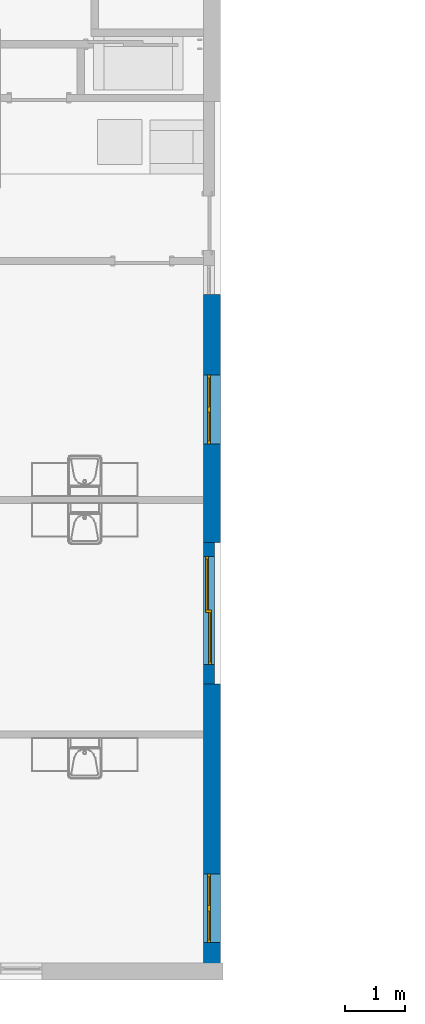
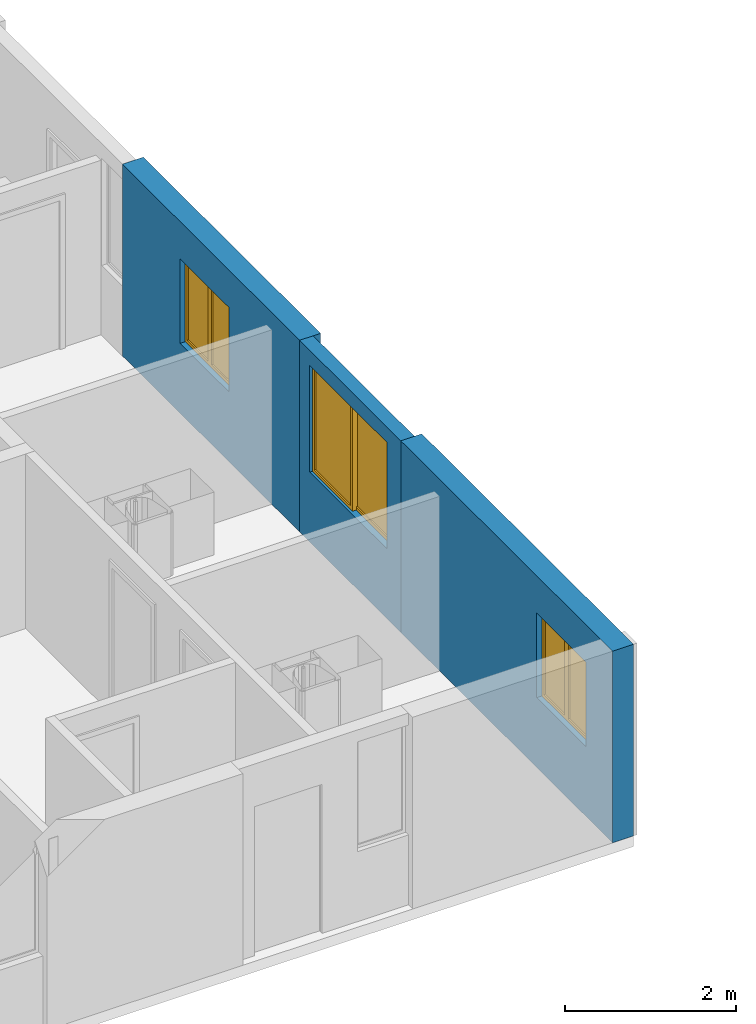
# One storey, part 9 of 64: 3 walls, 3 windows, 3 openings.
"""IFC4 building model written with IfcOpenShell, lengths in feet."""

from ifc_helpers import new_model, entity, si_unit, converted_unit, frame, origin_with_axes, origin_2d_with_axis, place, context, subcontext, project, spatial, line, indexed_curve, outline, extrude, polygons, source, transform, mapped, material, layer, layer_set, layer_usage, type_object, type_shapes, element, fill, save


model = new_model("IFC4")

# Units and contexts
model_context = context("Model", 3, precision=1e-05, world=origin_with_axes())
plan_context = context("Plan", 2, precision=1e-05, world=origin_2d_with_axis())
context_of_model_1 = context(None, 3, precision=1e-05, world=origin_with_axes())
context_of_model_2 = context(None, 3, precision=1e-05, world=origin_with_axes())
body_context = subcontext(model_context, "Body", "Model", "MODEL_VIEW")
ifc_project = project(units=[converted_unit("PLANEANGLEUNIT", "degree", entity("IfcReal", 0.0174532925199433), si_unit("PLANEANGLEUNIT", "RADIAN"), dimensions=[0, 0, 0, 0, 0, 0, 0]), converted_unit("AREAUNIT", "square foot", entity("IfcReal", 0.09290304), si_unit("AREAUNIT", "SQUARE_METRE"), dimensions=[2, 0, 0, 0, 0, 0, 0]), converted_unit("LENGTHUNIT", "foot", entity("IfcReal", 0.3048), si_unit("LENGTHUNIT", "METRE"), dimensions=[1, 0, 0, 0, 0, 0, 0]), converted_unit("VOLUMEUNIT", "cubic foot", entity("IfcReal", 0.0283168467116885), si_unit("VOLUMEUNIT", "CUBIC_METRE"), dimensions=[3, 0, 0, 0, 0, 0, 0])], contexts=[model_context, plan_context, context_of_model_1, context_of_model_2])

# Site, building, storey
site_placement = place(None, origin_with_axes())
site = spatial("IfcSite", under=ifc_project, at=site_placement)
building_placement = place(site_placement, origin_with_axes())
building = spatial("IfcBuilding", under=site, at=building_placement, Name="Building")
storey_placement = place(building_placement, origin_with_axes())
storey = spatial("IfcBuildingStorey", under=building, at=storey_placement, Name="Storey")

# Wall, opening, window
ifc_material_1 = material()
ifc_layer_1 = layer(ifc_material_1, 0.0520833333333333)
ifc_material_2 = material()
ifc_layer_2 = layer(ifc_material_2, 0.458332985639572)
ifc_layer_3 = layer(ifc_material_1, 0.0520833320915699)
ifc_material_3 = material(Name="SPACE")
ifc_layer_4 = layer(ifc_material_3, 0.0416669994592667, Name="Air Gap")
ifc_material_4 = material()
ifc_layer_5 = layer(ifc_material_4, 0.328083992004395)
ifc_layer_set_1 = layer_set([ifc_layer_1, ifc_layer_2, ifc_layer_3, ifc_layer_4, ifc_layer_5], Name="poche")
ifc_layer_usage_1 = layer_usage(ifc_layer_set_1, "AXIS2", "POSITIVE", 0.0)
wall_type_1 = type_object("IfcWallType", PredefinedType="STANDARD", material=ifc_layer_set_1)
wall_1_placement = place(storey_placement, frame((-241.163509098564, 4.3808694273781, 0.0), z_axis=(0.0, 0.0, 1.0), x_axis=(3.13916473260163e-07, -0.999999999999951, 0.0)))
wall_1 = element("IfcWall", 1, at=wall_1_placement, inside=storey, type_object=wall_type_1, material=ifc_layer_usage_1, Name="Wall", context=body_context, shape_type="SweptSolid", body=[
    extrude(outline(indexed_curve([(0.0, 0.0), (0.0, 0.932250642528137), (13.6428727412722, 0.932250642528137), (13.6428727412722, 0.0), (0.0, 0.0)], self_intersect=False)), origin_with_axes(), (0.0, 0.0, 1.0), 9.00000020900736),
])
shared_shape_1 = source(origin_with_axes(), body_context, "Body", "SweptSolid", [
    extrude(outline(indexed_curve([(0.0, 0.0), (3.77686476707458, 0.0), (3.77686476707458, 3.96558260917664), (0.0, 3.96558260917664)], segments=[line(1, 2, 3, 4, 1)])), frame((0.0, -0.328083992004395, 0.0), z_axis=(0.0, -1.0, 0.0), x_axis=(1.0, 0.0, 0.0)), (0.0, 0.0, -1.0), 1.58841864956333),
])
opening_1_placement = place(wall_1_placement, frame((4.44922429995878, -1.39668497240116e-06, 3.28083989501312), z_axis=(0.0, 0.0, 1.0), x_axis=(1.0, 5.29395592033938e-23, 0.0)))
opening_1 = element("IfcOpeningElement", 2, at=opening_1_placement, cuts=wall_1, Name="Opening", PredefinedType="OPENING", context=body_context, shape_type="MappedRepresentation", body=[
    mapped(shared_shape_1, transform((0.0, 0.0, 0.0), x_axis=(1.0, 0.0, 0.0), y_axis=(0.0, 1.0, 0.0), z_axis=(0.0, 0.0, 1.0), scale=1.0)),
])
window_type_1 = type_object("IfcWindowType", PartitioningType="NOTDEFINED", PredefinedType="NOTDEFINED")
shared_shape_2 = source(origin_with_axes(), body_context, "Body", "Tessellation", [
    polygons([(0.15000008046627, 0.164041996002197, 3.81558227539062), (0.15000008046627, 0.164041996002197, 0.149999901652336), (0.0, 0.164041996002197, 0.0), (0.0, 0.164041996002197, 3.96558260917664), (0.0, 0.0, 0.0), (0.0, 0.0, 3.96558260917664), (0.15000008046627, 7.7842932100225e-09, 3.81558227539062), (0.15000008046627, 7.7842932100225e-09, 0.149999901652336), (1.73843264579773, 6.58808829712143e-08, 3.81558227539062), (1.88843274116516, 7.36651841748426e-08, 0.0), (1.88843274116516, 7.36651841748426e-08, 3.96558260917664), (1.73843264579773, 6.58808829712143e-08, 0.149999901652336), (1.88843274116516, 0.164042070508003, 3.96558260917664), (1.88843274116516, 0.164042070508003, 0.0), (1.73843264579773, 0.164042070508003, 0.149999901652336), (1.73843264579773, 0.164042070508003, 3.81558227539062), (1.73843264579773, 0.0656168609857559, 0.149999901652336), (0.15000008046627, 0.0656168088316917, 3.81558227539062), (1.73843264579773, 0.0656168609857559, 3.81558227539062), (0.15000008046627, 0.0656168088316917, 0.149999901652336), (1.73843264579773, 0.0984252616763115, 3.81558227539062), (1.73843264579773, 0.0984252616763115, 0.149999901652336), (0.15000008046627, 0.0984252095222473, 0.149999901652336), (0.15000008046627, 0.0984252095222473, 3.81558227539062), (2.03843188285828, 0.164042085409164, 3.81558227539062), (2.03843188285828, 0.164042085409164, 0.149999901652336), (1.88843202590942, 0.164042085409164, 0.0), (1.88843202590942, 0.164042085409164, 3.96558260917664), (1.88843202590942, 8.25459736120138e-08, 0.0), (1.88843202590942, 8.25459736120138e-08, 3.96558260917664), (2.03843188285828, 9.03302606047873e-08, 3.81558227539062), (2.03843188285828, 9.03302606047873e-08, 0.149999901652336), (3.62686443328857, 1.48426849477801e-07, 3.81558227539062), (3.77686476707458, 1.56211143576002e-07, 0.0), (3.77686476707458, 1.56211143576002e-07, 3.96558260917664), (3.62686443328857, 1.48426849477801e-07, 0.149999901652336), (3.77686476707458, 0.16404215991497, 3.96558260917664), (3.77686476707458, 0.16404215991497, 0.0), (3.62686443328857, 0.16404215991497, 0.149999901652336), (3.62686443328857, 0.16404215991497, 3.81558227539062), (3.62686443328857, 0.0656169503927231, 0.149999901652336), (2.03843188285828, 0.0656168982386589, 3.81558227539062), (3.62686443328857, 0.0656169503927231, 3.81558227539062), (2.03843188285828, 0.0656168982386589, 0.149999901652336), (3.62686443328857, 0.0984253510832787, 3.81558227539062), (3.62686443328857, 0.0984253510832787, 0.149999901652336), (2.03843188285828, 0.0984252914786339, 0.149999901652336), (2.03843188285828, 0.0984252914786339, 3.81558227539062)], [[[2, 3, 1]], [[4, 1, 3]], [[5, 7, 6]], [[5, 8, 7]], [[10, 11, 9]], [[12, 10, 9]], [[7, 11, 6]], [[7, 9, 11]], [[8, 10, 12]], [[5, 10, 8]], [[14, 15, 13]], [[15, 16, 13]], [[16, 1, 13]], [[13, 1, 4]], [[14, 3, 2]], [[14, 2, 15]], [[3, 10, 5]], [[3, 14, 10]], [[11, 10, 14]], [[11, 14, 13]], [[8, 12, 15]], [[15, 2, 8]], [[15, 9, 16]], [[12, 9, 15]], [[4, 6, 11]], [[4, 11, 13]], [[5, 6, 4]], [[5, 4, 3]], [[1, 9, 7]], [[1, 16, 9]], [[7, 8, 2]], [[7, 2, 1]], [[26, 27, 25]], [[28, 25, 27]], [[29, 31, 30]], [[29, 32, 31]], [[34, 35, 33]], [[36, 34, 33]], [[31, 35, 30]], [[31, 33, 35]], [[32, 34, 36]], [[29, 34, 32]], [[38, 39, 37]], [[39, 40, 37]], [[40, 25, 37]], [[37, 25, 28]], [[38, 27, 26]], [[38, 26, 39]], [[27, 34, 29]], [[27, 38, 34]], [[35, 34, 38]], [[35, 38, 37]], [[32, 36, 39]], [[39, 26, 32]], [[39, 33, 40]], [[36, 33, 39]], [[28, 30, 35]], [[28, 35, 37]], [[29, 30, 28]], [[29, 28, 27]], [[25, 33, 31]], [[25, 40, 33]], [[31, 32, 26]], [[31, 26, 25]]]),
    polygons([(0.15000008046627, 0.164041996002197, 3.81558227539062), (0.15000008046627, 0.164041996002197, 0.149999901652336), (0.0, 0.164041996002197, 0.0), (0.0, 0.164041996002197, 3.96558260917664), (0.0, 0.0, 0.0), (0.0, 0.0, 3.96558260917664), (0.15000008046627, 7.7842932100225e-09, 3.81558227539062), (0.15000008046627, 7.7842932100225e-09, 0.149999901652336), (1.73843264579773, 6.58808829712143e-08, 3.81558227539062), (1.88843274116516, 7.36651841748426e-08, 0.0), (1.88843274116516, 7.36651841748426e-08, 3.96558260917664), (1.73843264579773, 6.58808829712143e-08, 0.149999901652336), (1.88843274116516, 0.164042070508003, 3.96558260917664), (1.88843274116516, 0.164042070508003, 0.0), (1.73843264579773, 0.164042070508003, 0.149999901652336), (1.73843264579773, 0.164042070508003, 3.81558227539062), (1.73843264579773, 0.0656168609857559, 0.149999901652336), (0.15000008046627, 0.0656168088316917, 3.81558227539062), (1.73843264579773, 0.0656168609857559, 3.81558227539062), (0.15000008046627, 0.0656168088316917, 0.149999901652336), (1.73843264579773, 0.0984252616763115, 3.81558227539062), (1.73843264579773, 0.0984252616763115, 0.149999901652336), (0.15000008046627, 0.0984252095222473, 0.149999901652336), (0.15000008046627, 0.0984252095222473, 3.81558227539062), (2.03843188285828, 0.164042085409164, 3.81558227539062), (2.03843188285828, 0.164042085409164, 0.149999901652336), (1.88843202590942, 0.164042085409164, 0.0), (1.88843202590942, 0.164042085409164, 3.96558260917664), (1.88843202590942, 8.25459736120138e-08, 0.0), (1.88843202590942, 8.25459736120138e-08, 3.96558260917664), (2.03843188285828, 9.03302606047873e-08, 3.81558227539062), (2.03843188285828, 9.03302606047873e-08, 0.149999901652336), (3.62686443328857, 1.48426849477801e-07, 3.81558227539062), (3.77686476707458, 1.56211143576002e-07, 0.0), (3.77686476707458, 1.56211143576002e-07, 3.96558260917664), (3.62686443328857, 1.48426849477801e-07, 0.149999901652336), (3.77686476707458, 0.16404215991497, 3.96558260917664), (3.77686476707458, 0.16404215991497, 0.0), (3.62686443328857, 0.16404215991497, 0.149999901652336), (3.62686443328857, 0.16404215991497, 3.81558227539062), (3.62686443328857, 0.0656169503927231, 0.149999901652336), (2.03843188285828, 0.0656168982386589, 3.81558227539062), (3.62686443328857, 0.0656169503927231, 3.81558227539062), (2.03843188285828, 0.0656168982386589, 0.149999901652336), (3.62686443328857, 0.0984253510832787, 3.81558227539062), (3.62686443328857, 0.0984253510832787, 0.149999901652336), (2.03843188285828, 0.0984252914786339, 0.149999901652336), (2.03843188285828, 0.0984252914786339, 3.81558227539062)], [[[17, 19, 18]], [[20, 17, 18]], [[22, 23, 21]], [[23, 24, 21]], [[19, 24, 18]], [[21, 24, 19]], [[18, 24, 20]], [[24, 23, 20]], [[23, 17, 20]], [[23, 22, 17]], [[21, 19, 17]], [[21, 17, 22]], [[41, 43, 42]], [[44, 41, 42]], [[46, 47, 45]], [[47, 48, 45]], [[43, 48, 42]], [[45, 48, 43]], [[42, 48, 44]], [[48, 47, 44]], [[47, 41, 44]], [[47, 46, 41]], [[45, 43, 41]], [[45, 41, 46]]]),
])
type_shapes(window_type_1, [shared_shape_2])
window_1_placement = place(opening_1_placement, frame((7.16061918425855e-08, 0.228105880457146, 2.91397119324188e-15), z_axis=(0.0, 0.0, 1.0), x_axis=(1.0, -7.19746150749534e-23, 0.0)))
window_1 = element("IfcWindow", 3, at=window_1_placement, inside=storey, type_object=window_type_1, Name="Window", context=body_context, shape_type="MappedRepresentation", body=[
    mapped(shared_shape_2, transform((0.0, 0.0, 0.0), x_axis=(1.0, 0.0, 0.0), y_axis=(0.0, 1.0, 0.0), z_axis=(0.0, 0.0, 1.0), scale=1.0)),
])
fill(opening_1, window_1)

ifc_layer_usage_2 = layer_usage(ifc_layer_set_1, "AXIS2", "POSITIVE", 0.0)
wall_2_placement = place(storey_placement, frame((-241.163509098564, -17.0450354498515, 0.0), z_axis=(0.0, 0.0, 1.0), x_axis=(3.13916473260163e-07, -0.999999999999951, 0.0)))
wall_2 = element("IfcWall", 4, at=wall_2_placement, inside=storey, type_object=wall_type_1, material=ifc_layer_usage_2, Name="Wall", context=body_context, shape_type="SweptSolid", body=[
    extrude(outline(indexed_curve([(0.0, 0.0), (0.0, 0.932250642528137), (16.2907788190314, 0.932250642528137), (16.2907788190314, 0.0), (0.0, 0.0)], self_intersect=False)), origin_with_axes(), (0.0, 0.0, 1.0), 9.00000020900736),
])
opening_2_placement = place(wall_2_placement, frame((10.455070831018, -3.28201915921582e-06, 3.28083989501312), z_axis=(0.0, 0.0, 1.0), x_axis=(1.0, 5.29395592033938e-23, 0.0)))
opening_2 = element("IfcOpeningElement", 5, at=opening_2_placement, cuts=wall_2, Name="Opening", PredefinedType="OPENING", context=body_context, shape_type="MappedRepresentation", body=[
    mapped(shared_shape_1, transform((0.0, 0.0, 0.0), x_axis=(1.0, 0.0, 0.0), y_axis=(0.0, 1.0, 0.0), z_axis=(0.0, 0.0, 1.0), scale=1.0)),
])
window_2_placement = place(opening_2_placement, frame((7.21169114510495e-08, 0.229732883884086, 2.91397119324188e-15), z_axis=(0.0, 0.0, 1.0), x_axis=(1.0, -7.19746150749534e-23, 0.0)))
window_2 = element("IfcWindow", 6, at=window_2_placement, inside=storey, type_object=window_type_1, Name="Window", context=body_context, shape_type="MappedRepresentation", body=[
    mapped(shared_shape_2, transform((0.0, 0.0, 0.0), x_axis=(1.0, 0.0, 0.0), y_axis=(0.0, 1.0, 0.0), z_axis=(0.0, 0.0, 1.0), scale=1.0)),
])
fill(opening_2, window_2)

ifc_layer_6 = layer(ifc_material_1, 0.0520833333333333)
ifc_layer_7 = layer(ifc_material_2, 0.458332985639572)
ifc_layer_8 = layer(ifc_material_1, 0.0520833320915699)
ifc_layer_9 = layer(ifc_material_3, 0.0416669994592667, Name="Siding")
ifc_layer_set_2 = layer_set([ifc_layer_6, ifc_layer_7, ifc_layer_8, ifc_layer_9], Name="poche")
ifc_layer_usage_3 = layer_usage(ifc_layer_set_2, "AXIS2", "POSITIVE", 0.0)
wall_type_2 = type_object("IfcWallType", PredefinedType="STANDARD", material=ifc_layer_set_2)
wall_3_placement = place(storey_placement, frame((-241.163484067742, -9.26200329788088, 0.0), z_axis=(0.0, 0.0, 1.0), x_axis=(3.13916473260163e-07, -0.999999999999951, 0.0)))
wall_3 = element("IfcWall", 7, at=wall_3_placement, inside=storey, type_object=wall_type_2, material=ifc_layer_usage_3, Name="Wall", context=body_context, shape_type="SweptSolid", body=[
    extrude(outline(indexed_curve([(0.0, 0.0), (0.0, 0.604166650523742), (7.78303383344548, 0.604166650523742), (7.78303383344548, 0.0), (0.0, 0.0)], self_intersect=False)), origin_with_axes(), (0.0, 0.0, 1.0), 9.00000020900736),
])
shared_shape_3 = source(origin_with_axes(), body_context, "Body", "SweptSolid", [
    extrude(outline(indexed_curve([(0.0, 0.0), (5.94525241851807, 0.0), (5.94525241851807, 5.0), (0.0, 5.0)], segments=[line(1, 2, 3, 4, 1)])), frame((0.0, -0.328083992004395, 0.0), z_axis=(0.0, -1.0, 0.0), x_axis=(1.0, 0.0, 0.0)), (0.0, 0.0, -1.0), 1.26033463072902),
])
opening_3_placement = place(wall_3_placement, frame((0.778056505158149, -2.44244962546094e-07, 3.28083989501312), z_axis=(0.0, 0.0, 1.0), x_axis=(1.0, 5.29395592033938e-23, 0.0)))
opening_3 = element("IfcOpeningElement", 8, at=opening_3_placement, cuts=wall_3, Name="Opening", PredefinedType="OPENING", context=body_context, shape_type="MappedRepresentation", body=[
    mapped(shared_shape_3, transform((0.0, 0.0, 0.0), x_axis=(1.0, 0.0, 0.0), y_axis=(0.0, 1.0, 0.0), z_axis=(0.0, 0.0, 1.0), scale=1.0)),
])
window_type_2 = type_object("IfcWindowType", PartitioningType="NOTDEFINED", PredefinedType="NOTDEFINED")
shared_shape_4 = source(origin_with_axes(), body_context, "Body", "Tessellation", [
    polygons([(0.15000008046627, 0.164041996002197, 4.84999990463257), (0.0, 0.164041996002197, 0.0), (0.15000008046627, 0.164041996002197, 0.149999901652336), (0.0, 0.164041996002197, 5.0), (0.0, 0.0, 0.0), (0.0, 0.0, 5.0), (0.15000008046627, 7.7842932100225e-09, 4.84999990463257), (0.15000008046627, 7.7842932100225e-09, 0.149999901652336), (2.94525122642517, -1.4012966786936e-08, 4.84999990463257), (3.0952513217926, -6.22866425104007e-09, 0.0), (3.0952513217926, -6.22866425104007e-09, 5.0), (2.94525122642517, -1.4012966786936e-08, 0.149999901652336), (3.0952513217926, 0.164041996002197, 5.0), (3.0952513217926, 0.164041996002197, 0.0), (2.94525122642517, 0.164041996002197, 0.149999901652336), (2.94525122642517, 0.164041996002197, 4.84999990463257), (3.09525156021118, 0.328078389167786, 4.84999990463257), (2.94525170326233, 0.328078389167786, 0.0), (3.09525156021118, 0.328078389167786, 0.149999901652336), (2.94525170326233, 0.328078389167786, 5.0), (2.94525170326233, 0.164036393165588, 0.0), (2.94525170326233, 0.164036393165588, 5.0), (3.09525156021118, 0.164036393165588, 4.84999990463257), (3.09525156021118, 0.164036393165588, 0.149999901652336), (5.79525232315063, 0.16403640806675, 4.84999990463257), (5.94525241851807, 0.16403640806675, 0.0), (5.94525241851807, 0.16403640806675, 5.0), (5.79525232315063, 0.16403640806675, 0.149999901652336), (5.94525241851807, 0.328078389167786, 5.0), (5.94525241851807, 0.328078389167786, 0.0), (5.79525232315063, 0.328078389167786, 0.149999901652336), (5.79525232315063, 0.328078389167786, 4.84999990463257), (2.94525122642517, 0.06561678647995, 0.149999901652336), (0.15000008046627, 0.0656168088316917, 4.84999990463257), (2.94525122642517, 0.06561678647995, 4.84999990463257), (0.15000008046627, 0.0656168088316917, 0.149999901652336), (2.94525122642517, 0.0984251797199249, 4.84999990463257), (2.94525122642517, 0.0984251797199249, 0.149999901652336), (0.15000008046627, 0.0984252095222473, 0.149999901652336), (0.15000008046627, 0.0984252095222473, 4.84999990463257), (5.79525232315063, 0.229653179645538, 0.149999901652336), (3.09525156021118, 0.229653179645538, 4.84999990463257), (5.79525232315063, 0.229653179645538, 4.84999990463257), (3.09525156021118, 0.229653179645538, 0.149999901652336), (5.79525232315063, 0.262461602687836, 4.84999990463257), (5.79525232315063, 0.262461602687836, 0.149999901652336), (3.09525156021118, 0.262461602687836, 0.149999901652336), (3.09525156021118, 0.262461602687836, 4.84999990463257)], [[[3, 2, 1]], [[2, 4, 1]], [[5, 7, 6]], [[5, 8, 7]], [[10, 11, 9]], [[12, 10, 9]], [[11, 6, 7]], [[9, 11, 7]], [[10, 12, 8]], [[10, 8, 5]], [[13, 14, 15]], [[15, 16, 13]], [[13, 16, 1]], [[13, 1, 4]], [[14, 2, 3]], [[14, 3, 15]], [[2, 10, 5]], [[2, 14, 10]], [[11, 10, 14]], [[13, 11, 14]], [[8, 12, 15]], [[15, 3, 8]], [[9, 16, 15]], [[9, 15, 12]], [[4, 6, 11]], [[13, 4, 11]], [[5, 6, 4]], [[5, 4, 2]], [[1, 9, 7]], [[1, 16, 9]], [[7, 8, 3]], [[1, 7, 3]], [[18, 17, 19]], [[20, 17, 18]], [[21, 23, 22]], [[21, 24, 23]], [[26, 27, 25]], [[28, 26, 25]], [[23, 27, 22]], [[23, 25, 27]], [[26, 28, 24]], [[21, 26, 24]], [[29, 30, 31]], [[29, 31, 32]], [[29, 32, 17]], [[29, 17, 20]], [[30, 18, 19]], [[30, 19, 31]], [[18, 26, 21]], [[18, 30, 26]], [[27, 26, 30]], [[27, 30, 29]], [[24, 28, 31]], [[19, 24, 31]], [[25, 32, 31]], [[28, 25, 31]], [[20, 22, 27]], [[29, 20, 27]], [[21, 22, 20]], [[21, 20, 18]], [[23, 17, 25]], [[17, 32, 25]], [[23, 24, 19]], [[17, 23, 19]]]),
    polygons([(0.15000008046627, 0.164041996002197, 4.84999990463257), (0.0, 0.164041996002197, 0.0), (0.15000008046627, 0.164041996002197, 0.149999901652336), (0.0, 0.164041996002197, 5.0), (0.0, 0.0, 0.0), (0.0, 0.0, 5.0), (0.15000008046627, 7.7842932100225e-09, 4.84999990463257), (0.15000008046627, 7.7842932100225e-09, 0.149999901652336), (2.94525122642517, -1.4012966786936e-08, 4.84999990463257), (3.0952513217926, -6.22866425104007e-09, 0.0), (3.0952513217926, -6.22866425104007e-09, 5.0), (2.94525122642517, -1.4012966786936e-08, 0.149999901652336), (3.0952513217926, 0.164041996002197, 5.0), (3.0952513217926, 0.164041996002197, 0.0), (2.94525122642517, 0.164041996002197, 0.149999901652336), (2.94525122642517, 0.164041996002197, 4.84999990463257), (3.09525156021118, 0.328078389167786, 4.84999990463257), (2.94525170326233, 0.328078389167786, 0.0), (3.09525156021118, 0.328078389167786, 0.149999901652336), (2.94525170326233, 0.328078389167786, 5.0), (2.94525170326233, 0.164036393165588, 0.0), (2.94525170326233, 0.164036393165588, 5.0), (3.09525156021118, 0.164036393165588, 4.84999990463257), (3.09525156021118, 0.164036393165588, 0.149999901652336), (5.79525232315063, 0.16403640806675, 4.84999990463257), (5.94525241851807, 0.16403640806675, 0.0), (5.94525241851807, 0.16403640806675, 5.0), (5.79525232315063, 0.16403640806675, 0.149999901652336), (5.94525241851807, 0.328078389167786, 5.0), (5.94525241851807, 0.328078389167786, 0.0), (5.79525232315063, 0.328078389167786, 0.149999901652336), (5.79525232315063, 0.328078389167786, 4.84999990463257), (2.94525122642517, 0.06561678647995, 0.149999901652336), (0.15000008046627, 0.0656168088316917, 4.84999990463257), (2.94525122642517, 0.06561678647995, 4.84999990463257), (0.15000008046627, 0.0656168088316917, 0.149999901652336), (2.94525122642517, 0.0984251797199249, 4.84999990463257), (2.94525122642517, 0.0984251797199249, 0.149999901652336), (0.15000008046627, 0.0984252095222473, 0.149999901652336), (0.15000008046627, 0.0984252095222473, 4.84999990463257), (5.79525232315063, 0.229653179645538, 0.149999901652336), (3.09525156021118, 0.229653179645538, 4.84999990463257), (5.79525232315063, 0.229653179645538, 4.84999990463257), (3.09525156021118, 0.229653179645538, 0.149999901652336), (5.79525232315063, 0.262461602687836, 4.84999990463257), (5.79525232315063, 0.262461602687836, 0.149999901652336), (3.09525156021118, 0.262461602687836, 0.149999901652336), (3.09525156021118, 0.262461602687836, 4.84999990463257)], [[[33, 35, 34]], [[36, 33, 34]], [[38, 39, 37]], [[39, 40, 37]], [[40, 34, 35]], [[37, 40, 35]], [[34, 40, 36]], [[40, 39, 36]], [[36, 39, 33]], [[39, 38, 33]], [[37, 35, 33]], [[37, 33, 38]], [[41, 43, 42]], [[41, 42, 44]], [[46, 47, 45]], [[45, 47, 48]], [[48, 42, 43]], [[48, 43, 45]], [[44, 42, 48]], [[44, 48, 47]], [[47, 41, 44]], [[47, 46, 41]], [[45, 43, 41]], [[45, 41, 46]]]),
])
type_shapes(window_type_2, [shared_shape_4])
window_3_placement = place(opening_3_placement, frame((3.64199207391761e-08, 0.11601785975197, 2.91397119324188e-15), z_axis=(0.0, 0.0, 1.0), x_axis=(1.0, -7.19746150749534e-23, 0.0)))
window_3 = element("IfcWindow", 9, at=window_3_placement, inside=storey, type_object=window_type_2, Name="Window", context=body_context, shape_type="MappedRepresentation", body=[
    mapped(shared_shape_4, transform((0.0, 0.0, 0.0), x_axis=(1.0, 0.0, 0.0), y_axis=(0.0, 1.0, 0.0), z_axis=(0.0, 0.0, 1.0), scale=1.0)),
])
fill(opening_3, window_3)

save(model, "model.ifc")
